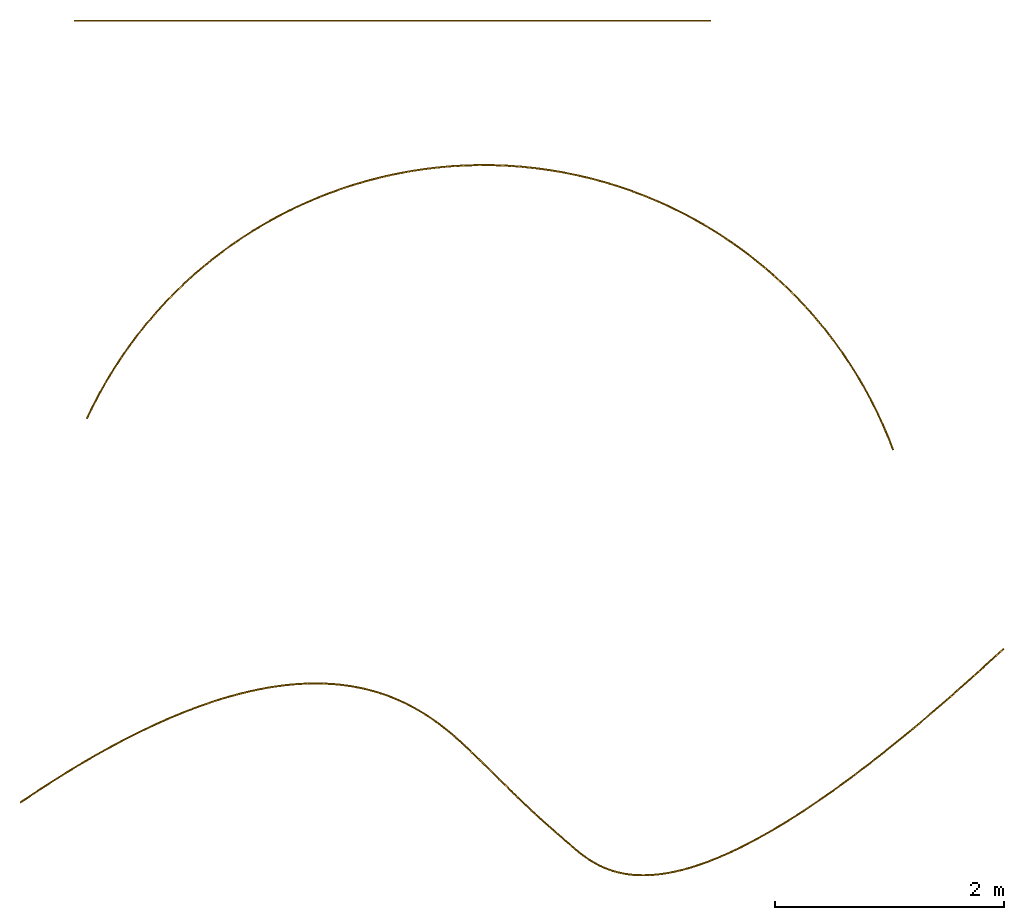
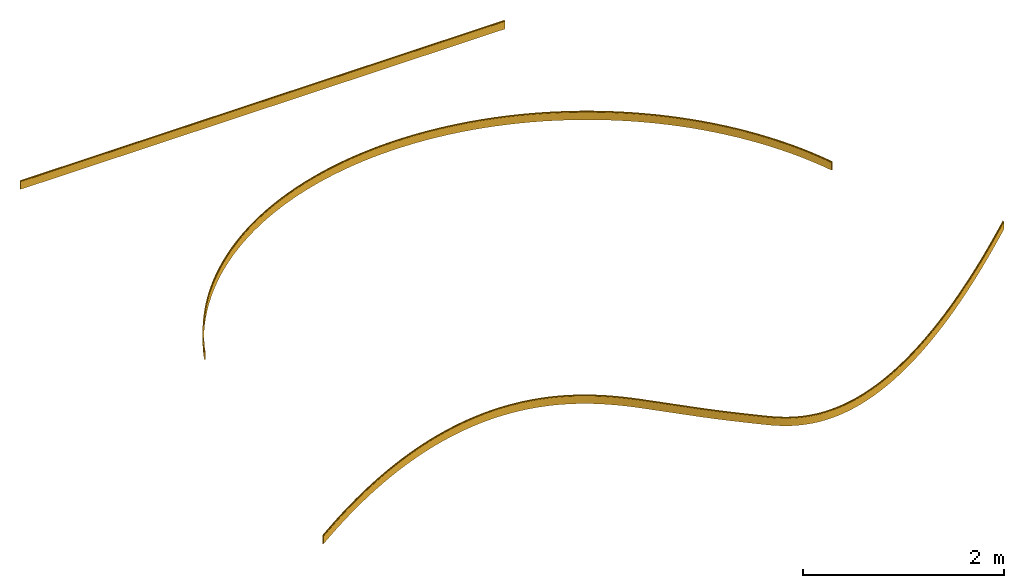
# One storey: 3 coverings.
"""IFC4 building model written with IfcOpenShell, lengths in feet."""

from ifc_helpers import new_model, entity, si_unit, converted_unit, derived_unit, direction, frame, origin_with_axes, place, context, subcontext, project, spatial, line, arc, indexed_curve, outline, extrude, material, type_object, element, save


model = new_model("IFC4")

# Units and contexts
model_context = context("Model", 3, precision=1e-05, world=origin_with_axes(), true_north=direction((0.0, 1.0)))
body_context = subcontext(model_context, "Body", "Model", "MODEL_VIEW", scale=1.0)
ifc_project = project(units=[converted_unit("LENGTHUNIT", "foot", entity("IfcReal", 30.48), si_unit("LENGTHUNIT", "METRE", prefix="CENTI"), dimensions=[1, 0, 0, 0, 0, 0, 0]), si_unit("AREAUNIT", "SQUARE_METRE"), si_unit("VOLUMEUNIT", "CUBIC_METRE"), si_unit("ABSORBEDDOSEUNIT", "GRAY"), si_unit("AMOUNTOFSUBSTANCEUNIT", "MOLE"), si_unit("DOSEEQUIVALENTUNIT", "SIEVERT"), si_unit("ELECTRICCAPACITANCEUNIT", "FARAD"), si_unit("ELECTRICCHARGEUNIT", "COULOMB"), si_unit("ELECTRICCONDUCTANCEUNIT", "SIEMENS"), si_unit("ELECTRICCURRENTUNIT", "AMPERE"), si_unit("ELECTRICRESISTANCEUNIT", "OHM"), si_unit("ELECTRICVOLTAGEUNIT", "VOLT"), si_unit("ENERGYUNIT", "JOULE"), si_unit("FORCEUNIT", "NEWTON"), si_unit("FREQUENCYUNIT", "HERTZ"), si_unit("ILLUMINANCEUNIT", "LUX"), si_unit("INDUCTANCEUNIT", "HENRY"), si_unit("LUMINOUSFLUXUNIT", "LUMEN"), si_unit("LUMINOUSINTENSITYUNIT", "CANDELA"), si_unit("MAGNETICFLUXDENSITYUNIT", "TESLA"), si_unit("MAGNETICFLUXUNIT", "WEBER"), si_unit("MASSUNIT", "GRAM"), converted_unit("PLANEANGLEUNIT", "degree", entity("IfcReal", 0.0174532925199433), si_unit("PLANEANGLEUNIT", "RADIAN"), dimensions=[0, 0, 0, 0, 0, 0, 0]), si_unit("POWERUNIT", "WATT"), si_unit("PRESSUREUNIT", "PASCAL"), si_unit("RADIOACTIVITYUNIT", "BECQUEREL"), si_unit("SOLIDANGLEUNIT", "STERADIAN"), si_unit("THERMODYNAMICTEMPERATUREUNIT", "KELVIN"), si_unit("TIMEUNIT", "SECOND"), derived_unit("ACCELERATIONUNIT", [(converted_unit("LENGTHUNIT", "foot", entity("IfcReal", 30.48), si_unit("LENGTHUNIT", "METRE", prefix="CENTI"), dimensions=[1, 0, 0, 0, 0, 0, 0]), 1), (si_unit("TIMEUNIT", "SECOND"), -2)]), derived_unit("ANGULARVELOCITYUNIT", [(converted_unit("PLANEANGLEUNIT", "degree", entity("IfcReal", 0.0174532925199433), si_unit("PLANEANGLEUNIT", "RADIAN"), dimensions=[0, 0, 0, 0, 0, 0, 0]), 1), (si_unit("TIMEUNIT", "SECOND"), -1)]), derived_unit("CURVATUREUNIT", [(converted_unit("PLANEANGLEUNIT", "degree", entity("IfcReal", 0.0174532925199433), si_unit("PLANEANGLEUNIT", "RADIAN"), dimensions=[0, 0, 0, 0, 0, 0, 0]), 1), (converted_unit("LENGTHUNIT", "foot", entity("IfcReal", 30.48), si_unit("LENGTHUNIT", "METRE", prefix="CENTI"), dimensions=[1, 0, 0, 0, 0, 0, 0]), -1)]), derived_unit("DYNAMICVISCOSITYUNIT", [(si_unit("PRESSUREUNIT", "PASCAL"), 1), (si_unit("TIMEUNIT", "SECOND"), 1)]), derived_unit("HEATFLUXDENSITYUNIT", [(si_unit("POWERUNIT", "WATT"), 1), (converted_unit("LENGTHUNIT", "foot", entity("IfcReal", 30.48), si_unit("LENGTHUNIT", "METRE", prefix="CENTI"), dimensions=[1, 0, 0, 0, 0, 0, 0]), -2)]), derived_unit("HEATINGVALUEUNIT", [(si_unit("ENERGYUNIT", "JOULE"), 1), (si_unit("MASSUNIT", "GRAM"), -1)]), derived_unit("INTEGERCOUNTRATEUNIT", [(si_unit("TIMEUNIT", "SECOND"), -1)]), derived_unit("IONCONCENTRATIONUNIT", [(si_unit("MASSUNIT", "GRAM"), 1), (si_unit("VOLUMEUNIT", "CUBIC_METRE"), -1)]), derived_unit("ISOTHERMALMOISTURECAPACITYUNIT", [(si_unit("VOLUMEUNIT", "CUBIC_METRE"), 1), (si_unit("MASSUNIT", "GRAM"), -1)]), derived_unit("KINEMATICVISCOSITYUNIT", [(si_unit("AREAUNIT", "SQUARE_METRE"), 1), (si_unit("TIMEUNIT", "SECOND"), -1)]), derived_unit("LINEARFORCEUNIT", [(si_unit("FORCEUNIT", "NEWTON"), 1), (converted_unit("LENGTHUNIT", "foot", entity("IfcReal", 30.48), si_unit("LENGTHUNIT", "METRE", prefix="CENTI"), dimensions=[1, 0, 0, 0, 0, 0, 0]), -1)]), derived_unit("LINEARMOMENTUNIT", [(si_unit("FORCEUNIT", "NEWTON"), 1), (converted_unit("LENGTHUNIT", "foot", entity("IfcReal", 30.48), si_unit("LENGTHUNIT", "METRE", prefix="CENTI"), dimensions=[1, 0, 0, 0, 0, 0, 0]), -1)]), derived_unit("LINEARSTIFFNESSUNIT", [(si_unit("FORCEUNIT", "NEWTON"), 1), (converted_unit("LENGTHUNIT", "foot", entity("IfcReal", 30.48), si_unit("LENGTHUNIT", "METRE", prefix="CENTI"), dimensions=[1, 0, 0, 0, 0, 0, 0]), -1)]), derived_unit("LINEARVELOCITYUNIT", [(converted_unit("LENGTHUNIT", "foot", entity("IfcReal", 30.48), si_unit("LENGTHUNIT", "METRE", prefix="CENTI"), dimensions=[1, 0, 0, 0, 0, 0, 0]), 1), (si_unit("TIMEUNIT", "SECOND"), -1)]), derived_unit("LUMINOUSINTENSITYDISTRIBUTIONUNIT", [(si_unit("LUMINOUSINTENSITYUNIT", "CANDELA"), 1), (si_unit("LUMINOUSFLUXUNIT", "LUMEN"), -1)]), derived_unit("MASSDENSITYUNIT", [(si_unit("MASSUNIT", "GRAM"), 1), (si_unit("VOLUMEUNIT", "CUBIC_METRE"), -1)]), derived_unit("MASSFLOWRATEUNIT", [(si_unit("MASSUNIT", "GRAM"), 1), (si_unit("TIMEUNIT", "SECOND"), -1)]), derived_unit("MASSPERLENGTHUNIT", [(si_unit("MASSUNIT", "GRAM"), 1), (converted_unit("LENGTHUNIT", "foot", entity("IfcReal", 30.48), si_unit("LENGTHUNIT", "METRE", prefix="CENTI"), dimensions=[1, 0, 0, 0, 0, 0, 0]), -1)]), derived_unit("MODULUSOFELASTICITYUNIT", [(si_unit("FORCEUNIT", "NEWTON"), 1), (si_unit("AREAUNIT", "SQUARE_METRE"), -1)]), derived_unit("MODULUSOFLINEARSUBGRADEREACTIONUNIT", [(si_unit("FORCEUNIT", "NEWTON"), 1), (converted_unit("LENGTHUNIT", "foot", entity("IfcReal", 30.48), si_unit("LENGTHUNIT", "METRE", prefix="CENTI"), dimensions=[1, 0, 0, 0, 0, 0, 0]), -2)]), derived_unit("MODULUSOFROTATIONALSUBGRADEREACTIONUNIT", [(si_unit("FORCEUNIT", "NEWTON"), 1), (converted_unit("LENGTHUNIT", "foot", entity("IfcReal", 30.48), si_unit("LENGTHUNIT", "METRE", prefix="CENTI"), dimensions=[1, 0, 0, 0, 0, 0, 0]), 1)]), derived_unit("MODULUSOFSUBGRADEREACTIONUNIT", [(si_unit("FORCEUNIT", "NEWTON"), 1), (si_unit("VOLUMEUNIT", "CUBIC_METRE"), -1)]), derived_unit("MOISTUREDIFFUSIVITYUNIT", [(si_unit("VOLUMEUNIT", "CUBIC_METRE"), 1), (si_unit("TIMEUNIT", "SECOND"), -1)]), derived_unit("MOLECULARWEIGHTUNIT", [(si_unit("MASSUNIT", "GRAM"), 1), (si_unit("AMOUNTOFSUBSTANCEUNIT", "MOLE"), -1)]), derived_unit("PLANARFORCEUNIT", [(si_unit("FORCEUNIT", "NEWTON"), 1), (converted_unit("LENGTHUNIT", "foot", entity("IfcReal", 30.48), si_unit("LENGTHUNIT", "METRE", prefix="CENTI"), dimensions=[1, 0, 0, 0, 0, 0, 0]), -2)]), derived_unit("ROTATIONALFREQUENCYUNIT", [(si_unit("TIMEUNIT", "SECOND"), -1)]), derived_unit("ROTATIONALMASSUNIT", [(si_unit("MASSUNIT", "GRAM"), 1), (converted_unit("LENGTHUNIT", "foot", entity("IfcReal", 30.48), si_unit("LENGTHUNIT", "METRE", prefix="CENTI"), dimensions=[1, 0, 0, 0, 0, 0, 0]), 2)]), derived_unit("ROTATIONALSTIFFNESSUNIT", [(si_unit("FORCEUNIT", "NEWTON"), 1), (converted_unit("LENGTHUNIT", "foot", entity("IfcReal", 30.48), si_unit("LENGTHUNIT", "METRE", prefix="CENTI"), dimensions=[1, 0, 0, 0, 0, 0, 0]), 1), (converted_unit("PLANEANGLEUNIT", "degree", entity("IfcReal", 0.0174532925199433), si_unit("PLANEANGLEUNIT", "RADIAN"), dimensions=[0, 0, 0, 0, 0, 0, 0]), -1)]), derived_unit("SECTIONAREAINTEGRALUNIT", [(converted_unit("LENGTHUNIT", "foot", entity("IfcReal", 30.48), si_unit("LENGTHUNIT", "METRE", prefix="CENTI"), dimensions=[1, 0, 0, 0, 0, 0, 0]), 5)]), derived_unit("SECTIONMODULUSUNIT", [(converted_unit("LENGTHUNIT", "foot", entity("IfcReal", 30.48), si_unit("LENGTHUNIT", "METRE", prefix="CENTI"), dimensions=[1, 0, 0, 0, 0, 0, 0]), 3)]), derived_unit("SHEARMODULUSUNIT", [(si_unit("FORCEUNIT", "NEWTON"), 1), (si_unit("AREAUNIT", "SQUARE_METRE"), -1)]), derived_unit("SOUNDPOWERUNIT", [(si_unit("ENERGYUNIT", "JOULE"), 1), (si_unit("TIMEUNIT", "SECOND"), -1)]), derived_unit("SPECIFICHEATCAPACITYUNIT", [(si_unit("FORCEUNIT", "NEWTON"), 1), (si_unit("MASSUNIT", "GRAM"), -1), (si_unit("THERMODYNAMICTEMPERATUREUNIT", "KELVIN"), -1)]), derived_unit("TEMPERATUREGRADIENTUNIT", [(si_unit("THERMODYNAMICTEMPERATUREUNIT", "KELVIN"), 1), (converted_unit("LENGTHUNIT", "foot", entity("IfcReal", 30.48), si_unit("LENGTHUNIT", "METRE", prefix="CENTI"), dimensions=[1, 0, 0, 0, 0, 0, 0]), -1)]), derived_unit("THERMALADMITTANCEUNIT", [(si_unit("POWERUNIT", "WATT"), 1), (si_unit("AREAUNIT", "SQUARE_METRE"), -1), (si_unit("THERMODYNAMICTEMPERATUREUNIT", "KELVIN"), -1)]), derived_unit("THERMALCONDUCTANCEUNIT", [(si_unit("POWERUNIT", "WATT"), 1), (converted_unit("LENGTHUNIT", "foot", entity("IfcReal", 30.48), si_unit("LENGTHUNIT", "METRE", prefix="CENTI"), dimensions=[1, 0, 0, 0, 0, 0, 0]), -1), (si_unit("THERMODYNAMICTEMPERATUREUNIT", "KELVIN"), -1)]), derived_unit("THERMALEXPANSIONCOEFFICIENTUNIT", [(si_unit("THERMODYNAMICTEMPERATUREUNIT", "KELVIN"), -1)]), derived_unit("THERMALRESISTANCEUNIT", [(si_unit("AREAUNIT", "SQUARE_METRE"), 1), (si_unit("POWERUNIT", "WATT"), -1)]), derived_unit("THERMALTRANSMITTANCEUNIT", [(si_unit("POWERUNIT", "WATT"), 1), (si_unit("AREAUNIT", "SQUARE_METRE"), -1), (si_unit("THERMODYNAMICTEMPERATUREUNIT", "KELVIN"), -1)]), derived_unit("TORQUEUNIT", [(si_unit("FORCEUNIT", "NEWTON"), 1), (converted_unit("LENGTHUNIT", "foot", entity("IfcReal", 30.48), si_unit("LENGTHUNIT", "METRE", prefix="CENTI"), dimensions=[1, 0, 0, 0, 0, 0, 0]), 1)]), derived_unit("VAPORPERMEABILITYUNIT", [(si_unit("MASSUNIT", "GRAM"), 1), (si_unit("TIMEUNIT", "SECOND"), -1)]), derived_unit("VOLUMETRICFLOWRATEUNIT", [(si_unit("VOLUMEUNIT", "CUBIC_METRE"), 1), (si_unit("TIMEUNIT", "SECOND"), -1)]), derived_unit("WARPINGCONSTANTUNIT", [(converted_unit("LENGTHUNIT", "foot", entity("IfcReal", 30.48), si_unit("LENGTHUNIT", "METRE", prefix="CENTI"), dimensions=[1, 0, 0, 0, 0, 0, 0]), 6)]), derived_unit("WARPINGMOMENTUNIT", [(si_unit("FORCEUNIT", "NEWTON"), 1), (converted_unit("LENGTHUNIT", "foot", entity("IfcReal", 30.48), si_unit("LENGTHUNIT", "METRE", prefix="CENTI"), dimensions=[1, 0, 0, 0, 0, 0, 0]), 2)])], contexts=[model_context])

# Site, building, storey
site_placement = place(None, origin_with_axes())
site = spatial("IfcSite", under=ifc_project, at=site_placement, CompositionType="ELEMENT")
building_placement = place(site_placement, origin_with_axes())
building = spatial("IfcBuilding", under=site, at=building_placement, Name="Bldg 1", CompositionType="ELEMENT")
storey_placement = place(building_placement, origin_with_axes())
storey = spatial("IfcBuildingStorey", under=building, at=storey_placement, Name="Floor 1", CompositionType="ELEMENT", Elevation=0.0)

# Coverings
ifc_material = material(Name="Stucco white")
covering_type = type_object("IfcCoveringType", Name="Base Molding", PredefinedType="NOTDEFINED")
covering_1_placement = place(storey_placement, frame((-18.3923046275816, 35.977421467852, 0.323845925572552), z_axis=(1.0, 0.0, 0.0), x_axis=(0.0, -1.0, 0.0)))
element("IfcCovering", 1, at=covering_1_placement, inside=storey, type_object=covering_type, material=ifc_material, Name="Base Molding", ObjectType="Profile", PredefinedType="NOTDEFINED", context=body_context, shape_type="SweptSolid", body=[
    extrude(outline(indexed_curve([(0.019234766497724, 0.019234766497724), (0.0282659745662303, 0.019234766497724), (0.0282659745662303, 0.323845925572552), (-0.0134006921004364, 0.323845925572552), (-0.0134006921004364, -0.00948740776078092), (-5.80936177322306e-19, -0.00948740776078092), (-1.12257993081788e-33, -1.83331215432803e-17), (0.0136010338250804, 0.00563373267264352)], segments=[line(1, 2, 3, 4, 5, 6, 7), arc(7, 8, 1)], self_intersect=False)), origin_with_axes(), (0.0, 0.0, 1.0), 18.2579241103335),
])
covering_2_placement = place(storey_placement, frame((-18.0328858825899, 24.5658333027505, 0.323845925572552), z_axis=(0.420122705283643, 0.90746730657647, 0.0), x_axis=(0.90746730657647, -0.420122705283643, 0.0)))
element("IfcCovering", 2, at=covering_2_placement, inside=storey, type_object=covering_type, material=ifc_material, Name="Base Molding", ObjectType="Profile", PredefinedType="NOTDEFINED", context=body_context, shape_type="SweptSolid", body=[
    entity("IfcRevolvedAreaSolid", entity("IfcArbitraryClosedProfileDef", "AREA", None, entity("IfcIndexedPolyCurve", entity("IfcCartesianPointList2D", [[0.0192347664977255, 0.019234766497724], [0.0282659745662318, 0.019234766497724], [0.0282659745662318, 0.323845925572552], [-0.0134006921004348, 0.323845925572552], [-0.0134006921004349, -0.00948740776078092], [1.52717919278508e-15, -0.00948740776078092], [1.5277601289624e-15, -1.83331215432803e-17], [0.013601033825082, 0.00563373267264352]]), [entity("IfcLineIndex", [1, 2, 3, 4, 5, 6, 7]), entity("IfcArcIndex", [7, 8, 1])], False)), entity("IfcAxis2Placement3D", entity("IfcCartesianPoint", [0.0, 0.0, 0.0]), entity("IfcDirection", [0.0, 0.0, 1.0]), entity("IfcDirection", [1.0, 0.0, 0.0])), entity("IfcAxis1Placement", entity("IfcCartesianPoint", [12.5409174474016, 0.323845925572552, 0.0]), entity("IfcDirection", [0.0, 1.0, 0.0])), 134.773678517696),
])
covering_3_placement = place(storey_placement, frame((-19.937295823537, 13.554455328676, 0.323845925572552), z_axis=(0.825898216200202, 0.563819240960545, 0.0), x_axis=(0.563819240960545, -0.825898216200202, 0.0)))
ifc_direction = entity("IfcDirection", [1.0, 0.0, 0.0])
element("IfcCovering", 3, at=covering_3_placement, inside=storey, type_object=covering_type, material=ifc_material, Name="Base Molding", ObjectType="Profile", PredefinedType="NOTDEFINED", context=body_context, shape_type="AdvancedSweptSolid", body=[
    entity("IfcSurfaceCurveSweptAreaSolid", entity("IfcArbitraryClosedProfileDef", "AREA", None, entity("IfcIndexedPolyCurve", entity("IfcCartesianPointList2D", [[0.304611159074828, 0.0326354585981584], [0.304611159074828, 0.0416666666666646], [-4.7742504030075e-17, 0.0416666666666647], [-4.7742504030075e-17, -1.98486243219216e-15], [0.333333333333333, -2.02267282280346e-15], [0.333333333333333, 0.0134006921004344], [0.323845925572552, 0.0134006921004344], [0.318212192899909, 0.0270017259255148]]), [entity("IfcLineIndex", [1, 2, 3, 4, 5, 6, 7]), entity("IfcArcIndex", [7, 8, 1])], False)), entity("IfcAxis2Placement3D", entity("IfcCartesianPoint", [0.0, 0.0, 0.0]), entity("IfcDirection", [0.0, 0.0, 1.0]), ifc_direction), entity("IfcIndexedPolyCurve", entity("IfcCartesianPointList3D", [[-0.0134006921004313, 0.323845925572552, -1.5277601289624e-15], [-0.00531071914887921, 0.323845925572552, 0.753789674752156], [0.0189554727794309, 0.323845925572552, 1.50723209017262], [0.0552738067981349, 0.323845925572552, 2.16422290741896], [0.107735801049036, 0.323845925572552, 2.82012205705336], [0.173296099316599, 0.323845925572552, 3.43945011737641], [0.255371801388924, 0.323845925572552, 4.05680656072318], [0.342319244643052, 0.323845925572552, 4.59270184772455], [0.445642860887023, 0.323845925572552, 5.12568200387014], [0.558787865092057, 0.323845925572552, 5.6238809199092], [0.688324022342114, 0.323845925572552, 6.11807150650908], [0.817161258947745, 0.323845925572552, 6.54714752534533], [0.96206685799791, 0.323845925572552, 6.9710668936696], [1.11269511582205, 0.323845925572552, 7.36156582319924], [1.27877214308469, 0.323845925572552, 7.74574899179793], [1.44133237512895, 0.323845925572552, 8.08200586639665], [1.61875416296607, 0.323845925572552, 8.41066377967101], [1.79657364236404, 0.323845925572552, 8.70715821179711], [1.9877660684016, 0.323845925572552, 8.99521058856394], [2.1763540798728, 0.323845925572552, 9.25187442566916], [2.3774511463759, 0.323845925572552, 9.49885971509362], [2.57215180414712, 0.323845925572552, 9.71540698382138], [2.77708051526488, 0.323845925572552, 9.92230137497206], [2.98387745868284, 0.323845925572552, 10.1114777096961], [3.19990417881175, 0.323845925572552, 10.2900417531567], [3.40129526703819, 0.323845925572553, 10.4408604292871], [3.60936924723361, 0.323845925572554, 10.5823166495548], [3.82571230471872, 0.323845925572553, 10.7154222912041], [4.04785963085802, 0.323845925572552, 10.8385969470795], [4.24544112004537, 0.323845925572552, 10.9376086142502], [4.44665701190218, 0.323845925572552, 11.0290083952656], [4.66333039386473, 0.323845925572552, 11.11789037962], [4.88306387309909, 0.323845925572552, 11.1989123500813], [5.06374756436426, 0.323845925572552, 11.2591346159341], [5.24599448504139, 0.323845925572552, 11.3144462557341], [5.45597277181411, 0.323845925572552, 11.3724023081199], [5.66726327611932, 0.323845925572552, 11.4253750153814], [5.79175408560718, 0.323845925572552, 11.454192549714], [5.91660037196947, 0.323845925572552, 11.4814288621204], [6.13924025327647, 0.323845925572552, 11.5276943839493], [6.36220421050311, 0.323845925572552, 11.5723719961989], [6.95247412988588, 0.323845925572552, 11.6887885475479], [7.54262056041636, 0.323845925572552, 11.805829487771], [7.72615939716671, 0.323845925572552, 11.8426552621641], [7.90957196244647, 0.323845925572552, 11.8801048703439], [8.16602085355813, 0.323845925572552, 11.9339944639788], [8.42202927521757, 0.323845925572552, 11.9899391696621], [8.62302285483087, 0.323845925572552, 12.0357835906887], [8.82353859977783, 0.323845925572552, 12.0836747799973], [8.96649196618941, 0.323845925572552, 12.1190594369447], [9.10922297165917, 0.323845925572552, 12.155330623764], [9.49847846867056, 0.323845925572552, 12.2560081188945], [9.88750409735265, 0.323845925572552, 12.3575702191477], [10.0342064031147, 0.323845925572552, 12.3970711135194], [10.1803814712925, 0.323845925572552, 12.4384804918684], [10.2622344387248, 0.323845925572552, 12.4632765203063], [10.3434914146857, 0.323845925572552, 12.4899608820461], [10.4802214285578, 0.323845925572552, 12.5399172562633], [10.6146863819032, 0.323845925572552, 12.5956838442908], [10.7323417467883, 0.323845925572552, 12.6508667713607], [10.8472139909323, 0.323845925572552, 12.7116311346965], [10.983996765283, 0.323845925572553, 12.7938511913426], [11.1154817026502, 0.323845925572554, 12.8843021521971], [11.2420724619743, 0.323845925572553, 12.9833031022727], [11.3624011898469, 0.323845925572552, 13.0898273047372], [11.4927164718266, 0.323845925572552, 13.2208511597453], [11.6140984681226, 0.323845925572552, 13.3601915138205], [11.7383924206836, 0.323845925572552, 13.5224292395982], [11.8527823751842, 0.323845925572552, 13.6917957198064], [11.9690814188859, 0.323845925572552, 13.8879600999035], [12.0738101620422, 0.323845925572552, 14.0905380403159], [12.1840424881112, 0.323845925572552, 14.3350923574401], [12.2820869106988, 0.323845925572552, 14.5847827075423], [12.3764313183441, 0.323845925572552, 14.8629718683127], [12.4581397541088, 0.323845925572552, 15.1451310573336], [12.542550981522, 0.323845925572552, 15.4891253286949], [12.6140441601452, 0.323845925572552, 15.8360345955834], [12.6779888032741, 0.323845925572552, 16.2134266325565], [12.7292941710125, 0.323845925572552, 16.5927436848976], [12.777204877321, 0.323845925572552, 17.0521957857005], [12.8123834872781, 0.323845925572552, 17.5127977115678], [12.8371277183432, 0.323845925572552, 18.006571436588], [12.8496999063218, 0.323845925572552, 18.5008048921337], [12.8513569934522, 0.323845925572552, 19.0916073341365], [12.840834255852, 0.323845925572552, 19.6823183831339], [12.8173996755698, 0.323845925572552, 20.3095655147183], [12.7823988641871, 0.323845925572552, 20.9362736500066], [12.7285327793725, 0.323845925572552, 21.6745247288482], [12.6631258296216, 0.323845925572552, 22.4118429379198], [12.5824579586407, 0.323845925572552, 23.1895735965512], [12.4908266404666, 0.323845925572552, 23.9660888792813], [12.3723709338596, 0.323845925572552, 24.8681045414924], [12.2429875723414, 0.323845925572552, 25.7686177035639]]), [entity("IfcArcIndex", [1, 2, 3]), entity("IfcArcIndex", [3, 4, 5]), entity("IfcArcIndex", [5, 6, 7]), entity("IfcArcIndex", [7, 8, 9]), entity("IfcArcIndex", [9, 10, 11]), entity("IfcArcIndex", [11, 12, 13]), entity("IfcArcIndex", [13, 14, 15]), entity("IfcArcIndex", [15, 16, 17]), entity("IfcArcIndex", [17, 18, 19]), entity("IfcArcIndex", [19, 20, 21]), entity("IfcArcIndex", [21, 22, 23]), entity("IfcArcIndex", [23, 24, 25]), entity("IfcArcIndex", [25, 26, 27]), entity("IfcArcIndex", [27, 28, 29]), entity("IfcArcIndex", [29, 30, 31]), entity("IfcArcIndex", [31, 32, 33]), entity("IfcArcIndex", [33, 34, 35]), entity("IfcArcIndex", [35, 36, 37]), entity("IfcArcIndex", [37, 38, 39]), entity("IfcArcIndex", [39, 40, 41]), entity("IfcArcIndex", [41, 42, 43]), entity("IfcArcIndex", [43, 44, 45]), entity("IfcArcIndex", [45, 46, 47]), entity("IfcArcIndex", [47, 48, 49]), entity("IfcArcIndex", [49, 50, 51]), entity("IfcArcIndex", [51, 52, 53]), entity("IfcArcIndex", [53, 54, 55]), entity("IfcArcIndex", [55, 56, 57]), entity("IfcArcIndex", [57, 58, 59]), entity("IfcArcIndex", [59, 60, 61]), entity("IfcArcIndex", [61, 62, 63]), entity("IfcArcIndex", [63, 64, 65]), entity("IfcArcIndex", [65, 66, 67]), entity("IfcArcIndex", [67, 68, 69]), entity("IfcArcIndex", [69, 70, 71]), entity("IfcArcIndex", [71, 72, 73]), entity("IfcArcIndex", [73, 74, 75]), entity("IfcArcIndex", [75, 76, 77]), entity("IfcArcIndex", [77, 78, 79]), entity("IfcArcIndex", [79, 80, 81]), entity("IfcArcIndex", [81, 82, 83]), entity("IfcArcIndex", [83, 84, 85]), entity("IfcArcIndex", [85, 86, 87]), entity("IfcArcIndex", [87, 88, 89]), entity("IfcArcIndex", [89, 90, 91]), entity("IfcArcIndex", [91, 92, 93])], False), None, None, entity("IfcPlane", entity("IfcAxis2Placement3D", entity("IfcCartesianPoint", [-1.69043790228645e-17, 0.323845925572552, 1.10066568106699e-17]), entity("IfcDirection", [0.0, -1.0, 0.0]), ifc_direction))),
])

save(model, "model.ifc")
